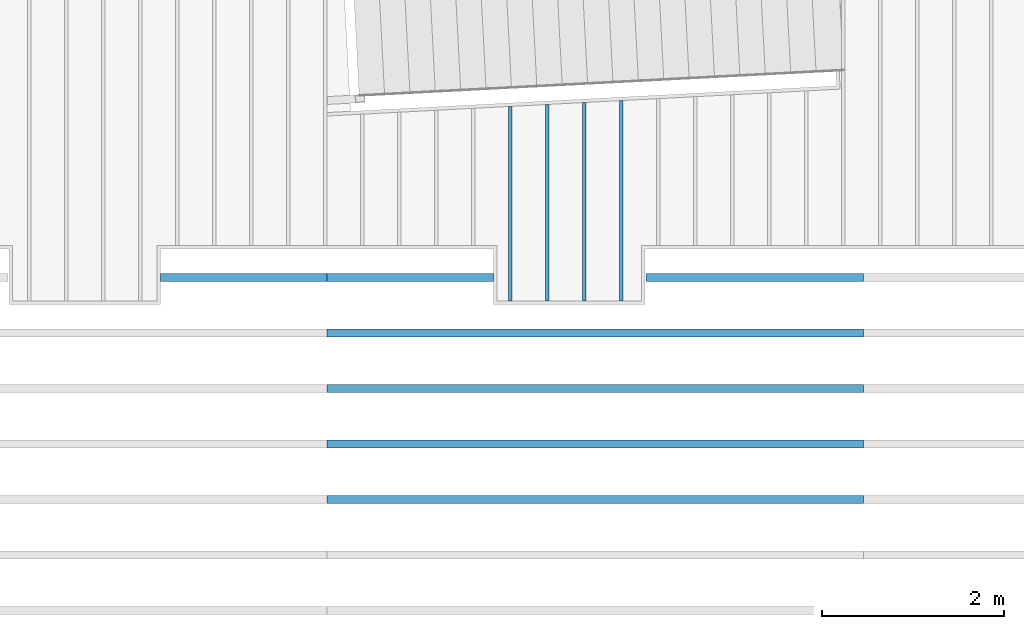
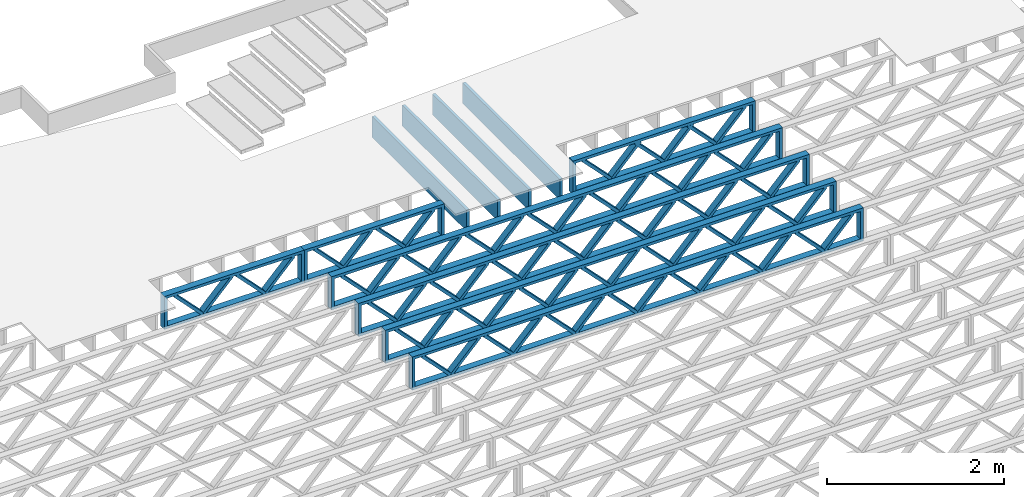
# One storey, part 9 of 23: 11 beams, 3 elements without a shape of their own.
"""IFC4 building model written with IfcOpenShell, lengths in feet."""

from ifc_helpers import new_model, entity, si_unit, converted_unit, derived_unit, direction, frame, frame_2d, origin, origin_2d_with_axis, place, context, subcontext, project, spatial, rectangle, extrude, source, transform, mapped, material, material_profile, profile_set, profile_usage, type_object, type_shapes, element, aggregate, save


model = new_model("IFC4")

# Units and contexts
model_context = context("Model", 3, precision=0.0001, world=origin(), true_north=direction((6.12303176911189e-17, 1.0)))
body_context = subcontext(model_context, "Body", "Model", "MODEL_VIEW")
ifc_project = project(units=[converted_unit("LENGTHUNIT", "FOOT", entity("IfcRatioMeasure", 0.3048), si_unit("LENGTHUNIT", "METRE"), dimensions=[1, 0, 0, 0, 0, 0, 0]), converted_unit("AREAUNIT", "SQUARE FOOT", entity("IfcRatioMeasure", 0.09290304), si_unit("AREAUNIT", "SQUARE_METRE"), dimensions=[2, 0, 0, 0, 0, 0, 0]), converted_unit("VOLUMEUNIT", "CUBIC FOOT", entity("IfcRatioMeasure", 0.028316846592), si_unit("VOLUMEUNIT", "CUBIC_METRE"), dimensions=[3, 0, 0, 0, 0, 0, 0]), converted_unit("PLANEANGLEUNIT", "DEGREE", entity("IfcRatioMeasure", 0.0174532925199433), si_unit("PLANEANGLEUNIT", "RADIAN"), dimensions=[0, 0, 0, 0, 0, 0, 0]), si_unit("MASSUNIT", "GRAM", prefix="KILO"), derived_unit("MASSDENSITYUNIT", [(si_unit("MASSUNIT", "GRAM", prefix="KILO"), 1), (si_unit("LENGTHUNIT", "METRE"), -3)]), derived_unit("MOMENTOFINERTIAUNIT", [(si_unit("LENGTHUNIT", "METRE"), 4)]), si_unit("TIMEUNIT", "SECOND"), si_unit("FREQUENCYUNIT", "HERTZ"), si_unit("THERMODYNAMICTEMPERATUREUNIT", "DEGREE_CELSIUS"), derived_unit("THERMALTRANSMITTANCEUNIT", [(si_unit("MASSUNIT", "GRAM", prefix="KILO"), 1), (si_unit("THERMODYNAMICTEMPERATUREUNIT", "KELVIN"), -1), (si_unit("TIMEUNIT", "SECOND"), -3)]), derived_unit("VOLUMETRICFLOWRATEUNIT", [(si_unit("LENGTHUNIT", "METRE"), 3), (si_unit("TIMEUNIT", "SECOND"), -1)]), si_unit("ELECTRICCURRENTUNIT", "AMPERE"), si_unit("ELECTRICVOLTAGEUNIT", "VOLT"), si_unit("POWERUNIT", "WATT"), si_unit("FORCEUNIT", "NEWTON"), si_unit("ILLUMINANCEUNIT", "LUX"), si_unit("LUMINOUSFLUXUNIT", "LUMEN"), si_unit("LUMINOUSINTENSITYUNIT", "CANDELA"), derived_unit("USERDEFINED", [(si_unit("MASSUNIT", "GRAM", prefix="KILO"), -1), (si_unit("LENGTHUNIT", "METRE"), -2), (si_unit("TIMEUNIT", "SECOND"), 3), (si_unit("LUMINOUSFLUXUNIT", "LUMEN"), 1)]), derived_unit("LINEARVELOCITYUNIT", [(si_unit("LENGTHUNIT", "METRE"), 1), (si_unit("TIMEUNIT", "SECOND"), -1)]), si_unit("PRESSUREUNIT", "PASCAL"), derived_unit("USERDEFINED", [(si_unit("LENGTHUNIT", "METRE"), -2), (si_unit("MASSUNIT", "GRAM", prefix="KILO"), 1), (si_unit("TIMEUNIT", "SECOND"), -2)]), derived_unit("LINEARFORCEUNIT", [(si_unit("MASSUNIT", "GRAM", prefix="KILO"), 1), (si_unit("LENGTHUNIT", "METRE"), 1), (si_unit("TIMEUNIT", "SECOND"), -2), (si_unit("LENGTHUNIT", "METRE"), -1)]), derived_unit("PLANARFORCEUNIT", [(si_unit("MASSUNIT", "GRAM", prefix="KILO"), 1), (si_unit("LENGTHUNIT", "METRE"), 1), (si_unit("TIMEUNIT", "SECOND"), -2), (si_unit("LENGTHUNIT", "METRE"), -2)])], contexts=[model_context])

# Site, building, storey
site_placement = place(None, origin())
site = spatial("IfcSite", under=ifc_project, at=site_placement, CompositionType="ELEMENT")
building_placement = place(site_placement, origin())
building = spatial("IfcBuilding", under=site, at=building_placement, CompositionType="ELEMENT")
storey_placement = place(building_placement, frame((0.0, 0.0, 10.8020833333333)))
storey = spatial("IfcBuildingStorey", under=building, at=storey_placement, Name="2ND FLOOR", CompositionType="ELEMENT", Elevation=10.8020833333333)

# Assembly, beams
assembly_1_placement = place(storey_placement, origin())
assembly_1 = element("IfcElementAssembly", 1, at=assembly_1_placement, inside=storey, Name="Structural Beam System:Structural Framing System", ObjectType="Structural Beam System:Structural Framing System", AssemblyPlace="NOTDEFINED", PredefinedType="BEAM_GRID")
ifc_material_1 = material(Name="WOOD TRUSS", Category="Materials")
ifc_material_profile_1 = material_profile(ifc_material_1, rectangle(XDim=1.73473973950632, YDim=0.125, at=frame_2d((-1.11022302462516e-16, 8.32667268468867e-17), x_axis=(1.0, 0.0))))
ifc_material_profile_2 = material_profile(ifc_material_1, rectangle(XDim=1.73473973950633, YDim=0.125, at=frame_2d((-1.11022302462516e-16, 8.32667268468867e-17), x_axis=(1.0, 0.0))))
ifc_material_profile_3 = material_profile(ifc_material_1, rectangle(XDim=1.73473973950632, YDim=0.125, at=frame_2d((-5.55111512312578e-17, 1.38777878078145e-16), x_axis=(1.0, 0.0))))
ifc_material_profile_4 = material_profile(ifc_material_1, rectangle(XDim=1.73473973950633, YDim=0.125, at=frame_2d((-1.11022302462516e-16, 8.32667268468867e-17), x_axis=(1.0, 0.0))))
ifc_material_profile_5 = material_profile(ifc_material_1, rectangle(XDim=1.73473973950632, YDim=0.125, at=frame_2d((-1.11022302462516e-16, 8.32667268468867e-17), x_axis=(1.0, 0.0))))
ifc_material_profile_6 = material_profile(ifc_material_1, rectangle(XDim=1.73473973950633, YDim=0.125, at=frame_2d((-2.77555756156289e-16, 3.05311331771918e-16), x_axis=(1.0, 0.0))))
ifc_material_profile_7 = material_profile(ifc_material_1, rectangle(XDim=1.73473973950632, YDim=0.124999999999999, at=frame_2d((-3.88578058618805e-16, -2.4980018054066e-16), x_axis=(1.0, 0.0))))
ifc_material_profile_8 = material_profile(ifc_material_1, rectangle(XDim=1.73473973950633, YDim=0.125, at=frame_2d((2.77555756156289e-16, -3.05311331771918e-16), x_axis=(1.0, 0.0))))
ifc_material_profile_9 = material_profile(ifc_material_1, rectangle(XDim=1.73473973950632, YDim=0.124999999999999, at=frame_2d((-1.11022302462516e-16, 8.32667268468867e-17), x_axis=(1.0, 0.0))))
ifc_material_profile_10 = material_profile(ifc_material_1, rectangle(XDim=1.73473973950633, YDim=0.125, at=origin_2d_with_axis()))
ifc_material_profile_11 = material_profile(ifc_material_1, rectangle(XDim=0.124999999999982, YDim=0.291666666666668, at=origin_2d_with_axis()))
ifc_material_profile_12 = material_profile(ifc_material_1, rectangle(XDim=0.124999999999932, YDim=0.291666666666664, at=origin_2d_with_axis()))
ifc_material_profile_13 = material_profile(ifc_material_1, rectangle(XDim=1.25000000000002, YDim=0.29166666666667, at=origin_2d_with_axis()))
ifc_material_profile_14 = material_profile(ifc_material_1, rectangle(XDim=1.25000000000004, YDim=0.291666666666667, at=origin_2d_with_axis()))
ifc_profile_set_1 = profile_set([ifc_material_profile_1, ifc_material_profile_2, ifc_material_profile_3, ifc_material_profile_4, ifc_material_profile_5, ifc_material_profile_6, ifc_material_profile_7, ifc_material_profile_8, ifc_material_profile_9, ifc_material_profile_10, ifc_material_profile_11, ifc_material_profile_12, ifc_material_profile_13, ifc_material_profile_14])
ifc_profile_usage_1 = profile_usage(ifc_profile_set_1, cardinal=8)
beam_type_1 = type_object("IfcBeamType", PredefinedType="BEAM", material=ifc_profile_set_1)
shared_shape_1 = source(origin(), body_context, "Body", "SweptSolid", [
    extrude(rectangle(XDim=1.73473973950632, YDim=0.125, at=frame_2d((-5.55111512312578e-17, 1.38777878078145e-16), x_axis=(1.0, 0.0))), frame((0.625142936836962, -0.145833333333334, 0.0), z_axis=(0.0, 1.0, 0.0), x_axis=(0.693383046997606, 0.0, 0.720569184836762)), (0.0, 0.0, 1.0), 0.291666666666667),
    extrude(rectangle(XDim=1.73473973950633, YDim=0.125, at=frame_2d((-1.11022302462516e-16, 8.32667268468867e-17), x_axis=(1.0, 0.0))), frame((-0.625142936836309, -0.145833333333334, 0.0), z_axis=(0.0, 1.0, 0.0), x_axis=(0.69338304699761, 0.0, -0.720569184836758)), (0.0, 0.0, 1.0), 0.291666666666667),
    extrude(rectangle(XDim=1.73473973950632, YDim=0.125, at=frame_2d((-1.11022302462516e-16, 8.32667268468867e-17), x_axis=(1.0, 0.0))), frame((2.87514283803796, -0.145833333333334, 0.0), z_axis=(0.0, 1.0, 0.0), x_axis=(0.693383046997606, 0.0, 0.720569184836762)), (0.0, 0.0, 1.0), 0.291666666666667),
    extrude(rectangle(XDim=1.73473973950633, YDim=0.125, at=frame_2d((-1.11022302462516e-16, 8.32667268468867e-17), x_axis=(1.0, 0.0))), frame((1.62485696436469, -0.145833333333334, 0.0), z_axis=(0.0, 1.0, 0.0), x_axis=(0.69338304699761, 0.0, -0.720569184836758)), (0.0, 0.0, 1.0), 0.291666666666667),
    extrude(rectangle(XDim=1.73473973950632, YDim=0.125, at=frame_2d((-1.11022302462516e-16, 8.32667268468867e-17), x_axis=(1.0, 0.0))), frame((-1.62485696436403, -0.145833333333334, 0.0), z_axis=(0.0, 1.0, 0.0), x_axis=(0.693383046997606, 0.0, 0.720569184836762)), (0.0, 0.0, 1.0), 0.291666666666667),
    extrude(rectangle(XDim=1.73473973950633, YDim=0.125, at=origin_2d_with_axis()), frame((-2.87514283803731, -0.145833333333334, 0.0), z_axis=(0.0, 1.0, 0.0), x_axis=(0.69338304699761, 0.0, -0.720569184836758)), (0.0, 0.0, 1.0), 0.291666666666667),
    extrude(rectangle(XDim=0.124999999999982, YDim=0.291666666666668, at=origin_2d_with_axis()), frame((-3.91666656786758, 0.0, 0.687500000000054), z_axis=(1.0, 0.0, 0.0), x_axis=(0.0, 0.0, -1.0)), (0.0, 0.0, 1.0), 7.83333313573516),
    extrude(rectangle(XDim=0.124999999999932, YDim=0.291666666666664, at=origin_2d_with_axis()), frame((-3.91666656786737, 0.0, -0.687499999999984), z_axis=(1.0, 0.0, 0.0), x_axis=(0.0, 0.0, -1.0)), (0.0, 0.0, 1.0), 7.83333313573495),
    extrude(rectangle(XDim=1.25000000000002, YDim=0.29166666666667, at=origin_2d_with_axis()), frame((3.79166656786756, 0.0, 0.0), z_axis=(1.0, 0.0, 0.0), x_axis=(0.0, 0.0, -1.0)), (0.0, 0.0, 1.0), 0.12500000000002),
    extrude(rectangle(XDim=1.25000000000004, YDim=0.291666666666667, at=origin_2d_with_axis()), frame((-3.91666656786758, 0.0, 0.0), z_axis=(1.0, 0.0, 0.0), x_axis=(0.0, 0.0, -1.0)), (0.0, 0.0, 1.0), 0.125000000000023),
])
type_shapes(beam_type_1, [shared_shape_1])
beam_1_placement = place(assembly_1_placement, frame((-168.321493720097, 957.861934882651, -0.947916666666657), z_axis=(0.0, 0.0, 1.0), x_axis=(-1.0, 0.0, 0.0)))
beam_1 = element("IfcBeam", 2, at=beam_1_placement, type_object=beam_type_1, material=ifc_profile_usage_1, PredefinedType="BEAM", context=body_context, shape_type="MappedRepresentation", body=[
    mapped(shared_shape_1, transform((0.0, 0.0, 0.0), scale=1.0)),
])
ifc_profile_usage_2 = profile_usage(ifc_profile_set_1, cardinal=8)
beam_type_2 = type_object("IfcBeamType", PredefinedType="BEAM", material=ifc_profile_set_1)
shared_shape_2 = source(origin(), body_context, "Body", "SweptSolid", [
    extrude(rectangle(XDim=1.73473973950632, YDim=0.125, at=frame_2d((0.0, 1.66533453693773e-16), x_axis=(1.0, 0.0))), frame((1.95847612494153, -0.145833333333334, 0.0), z_axis=(0.0, 1.0, 0.0), x_axis=(0.693383046997606, 0.0, 0.720569184836762)), (0.0, 0.0, 1.0), 0.291666666666667),
    extrude(rectangle(XDim=1.73473973950633, YDim=0.125, at=frame_2d((-5.55111512312578e-17, 8.32667268468867e-17), x_axis=(1.0, 0.0))), frame((0.708190251268258, -0.145833333333334, 0.0), z_axis=(0.0, 1.0, 0.0), x_axis=(0.69338304699761, 0.0, -0.720569184836758)), (0.0, 0.0, 1.0), 0.291666666666667),
    extrude(rectangle(XDim=1.73473973950632, YDim=0.125, at=frame_2d((0.0, 1.66533453693773e-16), x_axis=(1.0, 0.0))), frame((-0.708190251267602, -0.145833333333334, 0.0), z_axis=(0.0, 1.0, 0.0), x_axis=(0.693383046997606, 0.0, 0.720569184836762)), (0.0, 0.0, 1.0), 0.291666666666667),
    extrude(rectangle(XDim=1.73473973950633, YDim=0.125, at=frame_2d((-2.22044604925031e-16, 2.22044604925031e-16), x_axis=(1.0, 0.0))), frame((-1.95847612494087, -0.145833333333334, 0.0), z_axis=(0.0, 1.0, 0.0), x_axis=(0.69338304699761, 0.0, -0.720569184836758)), (0.0, 0.0, 1.0), 0.291666666666666),
    extrude(rectangle(XDim=0.124999999999982, YDim=0.291666666666668, at=origin_2d_with_axis()), frame((-2.99999985477115, 0.0, 0.687500000000054), z_axis=(1.0, 0.0, 0.0), x_axis=(0.0, 0.0, -1.0)), (0.0, 0.0, 1.0), 5.99999970954229),
    extrude(rectangle(XDim=0.124999999999932, YDim=0.291666666666664, at=origin_2d_with_axis()), frame((-2.99999985477093, 0.0, -0.687499999999984), z_axis=(1.0, 0.0, 0.0), x_axis=(0.0, 0.0, -1.0)), (0.0, 0.0, 1.0), 5.99999970954208),
    extrude(rectangle(XDim=1.25000000000002, YDim=0.29166666666667, at=origin_2d_with_axis()), frame((2.87499985477113, 0.0, 0.0), z_axis=(1.0, 0.0, 0.0), x_axis=(0.0, 0.0, -1.0)), (0.0, 0.0, 1.0), 0.12500000000002),
    extrude(rectangle(XDim=1.25000000000004, YDim=0.291666666666667, at=origin_2d_with_axis()), frame((-2.99999985477115, 0.0, 0.0), z_axis=(1.0, 0.0, 0.0), x_axis=(0.0, 0.0, -1.0)), (0.0, 0.0, 1.0), 0.125000000000023),
])
type_shapes(beam_type_2, [shared_shape_2])
beam_2_placement = place(assembly_1_placement, frame((-180.738160630791, 957.861934882651, -0.947916666666648), z_axis=(0.0, 0.0, 1.0), x_axis=(-1.0, 0.0, 0.0)))
beam_2 = element("IfcBeam", 3, at=beam_2_placement, type_object=beam_type_2, material=ifc_profile_usage_2, PredefinedType="BEAM", context=body_context, shape_type="MappedRepresentation", body=[
    mapped(shared_shape_2, transform((0.0, 0.0, 0.0), scale=1.0)),
])
ifc_profile_usage_3 = profile_usage(ifc_profile_set_1, cardinal=8)
beam_type_3 = type_object("IfcBeamType", PredefinedType="BEAM", material=ifc_profile_set_1)
shared_shape_3 = source(origin(), body_context, "Body", "SweptSolid", [
    extrude(rectangle(XDim=1.73473973950632, YDim=0.124999999999999, at=frame_2d((5.55111512312578e-16, 7.21644966006352e-16), x_axis=(1.0, 0.0))), frame((5.95847627016997, -0.145833333333334, 0.0), z_axis=(0.0, 1.0, 0.0), x_axis=(0.693383046997606, 0.0, 0.720569184836762)), (0.0, 0.0, 1.0), 0.291666666666667),
    extrude(rectangle(XDim=1.73473973950633, YDim=0.125, at=origin_2d_with_axis()), frame((4.7081903964967, -0.145833333333334, 0.0), z_axis=(0.0, 1.0, 0.0), x_axis=(0.69338304699761, 0.0, -0.720569184836758)), (0.0, 0.0, 1.0), 0.291666666666666),
    extrude(rectangle(XDim=1.73473973950632, YDim=0.125, at=frame_2d((2.22044604925031e-16, 3.88578058618805e-16), x_axis=(1.0, 0.0))), frame((3.29180960350347, -0.145833333333334, 0.0), z_axis=(0.0, 1.0, 0.0), x_axis=(0.693383046997606, 0.0, 0.720569184836762)), (0.0, 0.0, 1.0), 0.291666666666667),
    extrude(rectangle(XDim=1.73473973950633, YDim=0.125, at=frame_2d((1.11022302462516e-16, -8.32667268468867e-17), x_axis=(1.0, 0.0))), frame((2.0415237298302, -0.145833333333334, 0.0), z_axis=(0.0, 1.0, 0.0), x_axis=(0.69338304699761, 0.0, -0.720569184836758)), (0.0, 0.0, 1.0), 0.291666666666667),
    extrude(rectangle(XDim=1.73473973950632, YDim=0.125, at=frame_2d((-5.55111512312578e-17, 1.38777878078145e-16), x_axis=(1.0, 0.0))), frame((0.625142936836964, -0.145833333333334, 0.0), z_axis=(0.0, 1.0, 0.0), x_axis=(0.693383046997606, 0.0, 0.720569184836762)), (0.0, 0.0, 1.0), 0.291666666666667),
    extrude(rectangle(XDim=1.73473973950633, YDim=0.125, at=frame_2d((-1.11022302462516e-16, 8.32667268468867e-17), x_axis=(1.0, 0.0))), frame((-0.625142936836306, -0.145833333333334, 0.0), z_axis=(0.0, 1.0, 0.0), x_axis=(0.69338304699761, 0.0, -0.720569184836758)), (0.0, 0.0, 1.0), 0.291666666666667),
    extrude(rectangle(XDim=1.73473973950632, YDim=0.125, at=frame_2d((-1.11022302462516e-16, 8.32667268468867e-17), x_axis=(1.0, 0.0))), frame((-2.04152372982954, -0.145833333333334, 0.0), z_axis=(0.0, 1.0, 0.0), x_axis=(0.693383046997606, 0.0, 0.720569184836762)), (0.0, 0.0, 1.0), 0.291666666666667),
    extrude(rectangle(XDim=1.73473973950633, YDim=0.125, at=origin_2d_with_axis()), frame((-3.29180960350281, -0.145833333333334, 0.0), z_axis=(0.0, 1.0, 0.0), x_axis=(0.69338304699761, 0.0, -0.720569184836758)), (0.0, 0.0, 1.0), 0.291666666666667),
    extrude(rectangle(XDim=1.73473973950632, YDim=0.124999999999999, at=frame_2d((-1.11022302462516e-16, 8.32667268468867e-17), x_axis=(1.0, 0.0))), frame((-4.70819039649604, -0.145833333333334, 0.0), z_axis=(0.0, 1.0, 0.0), x_axis=(0.693383046997606, 0.0, 0.720569184836762)), (0.0, 0.0, 1.0), 0.291666666666667),
    extrude(rectangle(XDim=1.73473973950633, YDim=0.125, at=frame_2d((-5.55111512312578e-16, 6.38378239159465e-16), x_axis=(1.0, 0.0))), frame((-5.95847627016931, -0.145833333333334, 0.0), z_axis=(0.0, 1.0, 0.0), x_axis=(0.69338304699761, 0.0, -0.720569184836758)), (0.0, 0.0, 1.0), 0.291666666666666),
    extrude(rectangle(XDim=1.73473973950632, YDim=0.125, at=frame_2d((-7.21644966006352e-16, -5.82867087928207e-16), x_axis=(1.0, 0.0))), frame((8.62514293683647, -0.145833333333334, 0.0), z_axis=(0.0, 1.0, 0.0), x_axis=(0.693383046997607, 0.0, 0.720569184836761)), (0.0, 0.0, 1.0), 0.291666666666667),
    extrude(rectangle(XDim=1.73473973950633, YDim=0.125, at=origin_2d_with_axis()), frame((7.3748570631632, -0.145833333333334, 0.0), z_axis=(0.0, 1.0, 0.0), x_axis=(0.69338304699761, 0.0, -0.720569184836758)), (0.0, 0.0, 1.0), 0.291666666666666),
    extrude(rectangle(XDim=1.73473973950632, YDim=0.124999999999999, at=frame_2d((-1.11022302462516e-16, 8.32667268468867e-17), x_axis=(1.0, 0.0))), frame((-7.37485706316255, -0.145833333333334, 0.0), z_axis=(0.0, 1.0, 0.0), x_axis=(0.693383046997606, 0.0, 0.720569184836762)), (0.0, 0.0, 1.0), 0.291666666666667),
    extrude(rectangle(XDim=1.73473973950633, YDim=0.125, at=origin_2d_with_axis()), frame((-8.62514293683582, -0.145833333333334, 0.0), z_axis=(0.0, 1.0, 0.0), x_axis=(0.69338304699761, 0.0, -0.720569184836758)), (0.0, 0.0, 1.0), 0.291666666666666),
    extrude(rectangle(XDim=0.124999999999982, YDim=0.291666666666668, at=origin_2d_with_axis()), frame((-9.66666666666609, 0.0, 0.687500000000054), z_axis=(1.0, 0.0, 0.0), x_axis=(0.0, 0.0, -1.0)), (0.0, 0.0, 1.0), 19.3333333333322),
    extrude(rectangle(XDim=0.124999999999932, YDim=0.291666666666664, at=origin_2d_with_axis()), frame((-9.66666666666588, 0.0, -0.687499999999984), z_axis=(1.0, 0.0, 0.0), x_axis=(0.0, 0.0, -1.0)), (0.0, 0.0, 1.0), 19.333333333332),
    extrude(rectangle(XDim=1.25000000000002, YDim=0.29166666666667, at=origin_2d_with_axis()), frame((9.54166666666607, 0.0, 0.0), z_axis=(1.0, 0.0, 0.0), x_axis=(0.0, 0.0, -1.0)), (0.0, 0.0, 1.0), 0.12500000000002),
    extrude(rectangle(XDim=1.25000000000004, YDim=0.291666666666667, at=origin_2d_with_axis()), frame((-9.66666666666609, 0.0, 0.0), z_axis=(1.0, 0.0, 0.0), x_axis=(0.0, 0.0, -1.0)), (0.0, 0.0, 1.0), 0.125000000000023),
])
type_shapes(beam_type_3, [shared_shape_3])
beam_3_placement = place(assembly_1_placement, frame((-174.071493818896, 953.861934882651, -0.947916666666657), z_axis=(0.0, 0.0, 1.0), x_axis=(-1.0, 0.0, 0.0)))
beam_3 = element("IfcBeam", 4, at=beam_3_placement, type_object=beam_type_3, material=ifc_profile_usage_3, PredefinedType="BEAM", context=body_context, shape_type="MappedRepresentation", body=[
    mapped(shared_shape_3, transform((0.0, 0.0, 0.0), scale=1.0)),
])
ifc_profile_usage_4 = profile_usage(ifc_profile_set_1, cardinal=8)
beam_4_placement = place(assembly_1_placement, frame((-174.071493818896, 951.861934882651, -0.947916666666657), z_axis=(0.0, 0.0, 1.0), x_axis=(-1.0, 0.0, 0.0)))
beam_4 = element("IfcBeam", 5, at=beam_4_placement, type_object=beam_type_3, material=ifc_profile_usage_4, PredefinedType="BEAM", context=body_context, shape_type="MappedRepresentation", body=[
    mapped(shared_shape_3, transform((0.0, 0.0, 0.0), scale=1.0)),
])
ifc_profile_usage_5 = profile_usage(ifc_profile_set_1, cardinal=8)
beam_5_placement = place(assembly_1_placement, frame((-174.071493818896, 949.861934882651, -0.947916666666657), z_axis=(0.0, 0.0, 1.0), x_axis=(-1.0, 0.0, 0.0)))
beam_5 = element("IfcBeam", 6, at=beam_5_placement, type_object=beam_type_3, material=ifc_profile_usage_5, PredefinedType="BEAM", context=body_context, shape_type="MappedRepresentation", body=[
    mapped(shared_shape_3, transform((0.0, 0.0, 0.0), scale=1.0)),
])
ifc_profile_usage_6 = profile_usage(ifc_profile_set_1, cardinal=8)
beam_type_4 = type_object("IfcBeamType", PredefinedType="BEAM", material=ifc_profile_set_1)
shared_shape_4 = source(origin(), body_context, "Body", "SweptSolid", [
    extrude(rectangle(XDim=1.73473973950632, YDim=0.124999999999999, at=frame_2d((5.55111512312578e-16, 7.21644966006352e-16), x_axis=(1.0, 0.0))), frame((5.95847627016997, -0.145833333333334, 0.0), z_axis=(0.0, 1.0, 0.0), x_axis=(0.693383046997606, 0.0, 0.720569184836762)), (0.0, 0.0, 1.0), 0.291666666666667),
    extrude(rectangle(XDim=1.73473973950633, YDim=0.125, at=origin_2d_with_axis()), frame((4.7081903964967, -0.145833333333334, 0.0), z_axis=(0.0, 1.0, 0.0), x_axis=(0.69338304699761, 0.0, -0.720569184836758)), (0.0, 0.0, 1.0), 0.291666666666666),
    extrude(rectangle(XDim=1.73473973950632, YDim=0.125, at=frame_2d((2.22044604925031e-16, 3.88578058618805e-16), x_axis=(1.0, 0.0))), frame((3.29180960350347, -0.145833333333334, 0.0), z_axis=(0.0, 1.0, 0.0), x_axis=(0.693383046997606, 0.0, 0.720569184836762)), (0.0, 0.0, 1.0), 0.291666666666667),
    extrude(rectangle(XDim=1.73473973950633, YDim=0.125, at=frame_2d((1.11022302462516e-16, -8.32667268468867e-17), x_axis=(1.0, 0.0))), frame((2.0415237298302, -0.145833333333334, 0.0), z_axis=(0.0, 1.0, 0.0), x_axis=(0.69338304699761, 0.0, -0.720569184836758)), (0.0, 0.0, 1.0), 0.291666666666667),
    extrude(rectangle(XDim=1.73473973950632, YDim=0.125, at=frame_2d((-5.55111512312578e-17, 1.38777878078145e-16), x_axis=(1.0, 0.0))), frame((0.625142936836964, -0.145833333333334, 0.0), z_axis=(0.0, 1.0, 0.0), x_axis=(0.693383046997606, 0.0, 0.720569184836762)), (0.0, 0.0, 1.0), 0.291666666666667),
    extrude(rectangle(XDim=1.73473973950633, YDim=0.125, at=frame_2d((-1.11022302462516e-16, 8.32667268468867e-17), x_axis=(1.0, 0.0))), frame((-0.625142936836306, -0.145833333333334, 0.0), z_axis=(0.0, 1.0, 0.0), x_axis=(0.69338304699761, 0.0, -0.720569184836758)), (0.0, 0.0, 1.0), 0.291666666666667),
    extrude(rectangle(XDim=1.73473973950632, YDim=0.125, at=frame_2d((-1.11022302462516e-16, 8.32667268468867e-17), x_axis=(1.0, 0.0))), frame((-2.04152372982954, -0.145833333333334, 0.0), z_axis=(0.0, 1.0, 0.0), x_axis=(0.693383046997606, 0.0, 0.720569184836762)), (0.0, 0.0, 1.0), 0.291666666666667),
    extrude(rectangle(XDim=1.73473973950633, YDim=0.125, at=origin_2d_with_axis()), frame((-3.29180960350281, -0.145833333333334, 0.0), z_axis=(0.0, 1.0, 0.0), x_axis=(0.69338304699761, 0.0, -0.720569184836758)), (0.0, 0.0, 1.0), 0.291666666666667),
    extrude(rectangle(XDim=1.73473973950632, YDim=0.124999999999999, at=frame_2d((-1.11022302462516e-16, 8.32667268468867e-17), x_axis=(1.0, 0.0))), frame((-4.70819039649604, -0.145833333333334, 0.0), z_axis=(0.0, 1.0, 0.0), x_axis=(0.693383046997606, 0.0, 0.720569184836762)), (0.0, 0.0, 1.0), 0.291666666666667),
    extrude(rectangle(XDim=1.73473973950633, YDim=0.125, at=frame_2d((-5.55111512312578e-16, 6.38378239159465e-16), x_axis=(1.0, 0.0))), frame((-5.95847627016931, -0.145833333333334, 0.0), z_axis=(0.0, 1.0, 0.0), x_axis=(0.69338304699761, 0.0, -0.720569184836758)), (0.0, 0.0, 1.0), 0.291666666666666),
    extrude(rectangle(XDim=1.73473973950632, YDim=0.125, at=frame_2d((-7.21644966006352e-16, -5.82867087928207e-16), x_axis=(1.0, 0.0))), frame((8.62514293683647, -0.145833333333334, 0.0), z_axis=(0.0, 1.0, 0.0), x_axis=(0.693383046997607, 0.0, 0.720569184836761)), (0.0, 0.0, 1.0), 0.291666666666667),
    extrude(rectangle(XDim=1.73473973950633, YDim=0.125, at=origin_2d_with_axis()), frame((7.3748570631632, -0.145833333333334, 0.0), z_axis=(0.0, 1.0, 0.0), x_axis=(0.69338304699761, 0.0, -0.720569184836758)), (0.0, 0.0, 1.0), 0.291666666666666),
    extrude(rectangle(XDim=1.73473973950632, YDim=0.124999999999999, at=frame_2d((-1.11022302462516e-16, 8.32667268468867e-17), x_axis=(1.0, 0.0))), frame((-7.37485706316255, -0.145833333333334, 0.0), z_axis=(0.0, 1.0, 0.0), x_axis=(0.693383046997606, 0.0, 0.720569184836762)), (0.0, 0.0, 1.0), 0.291666666666667),
    extrude(rectangle(XDim=1.73473973950633, YDim=0.125, at=origin_2d_with_axis()), frame((-8.62514293683582, -0.145833333333334, 0.0), z_axis=(0.0, 1.0, 0.0), x_axis=(0.69338304699761, 0.0, -0.720569184836758)), (0.0, 0.0, 1.0), 0.291666666666666),
    extrude(rectangle(XDim=0.124999999999982, YDim=0.291666666666668, at=origin_2d_with_axis()), frame((-9.66666666666609, 0.0, 0.687500000000054), z_axis=(1.0, 0.0, 0.0), x_axis=(0.0, 0.0, -1.0)), (0.0, 0.0, 1.0), 19.3333333333322),
    extrude(rectangle(XDim=0.124999999999932, YDim=0.291666666666664, at=origin_2d_with_axis()), frame((-9.66666666666588, 0.0, -0.687499999999984), z_axis=(1.0, 0.0, 0.0), x_axis=(0.0, 0.0, -1.0)), (0.0, 0.0, 1.0), 19.333333333332),
    extrude(rectangle(XDim=1.25000000000002, YDim=0.29166666666667, at=origin_2d_with_axis()), frame((9.54166666666607, 0.0, 0.0), z_axis=(1.0, 0.0, 0.0), x_axis=(0.0, 0.0, -1.0)), (0.0, 0.0, 1.0), 0.12500000000002),
    extrude(rectangle(XDim=1.25000000000004, YDim=0.291666666666667, at=origin_2d_with_axis()), frame((-9.66666666666609, 0.0, 0.0), z_axis=(1.0, 0.0, 0.0), x_axis=(0.0, 0.0, -1.0)), (0.0, 0.0, 1.0), 0.125000000000023),
])
type_shapes(beam_type_4, [shared_shape_4])
beam_6_placement = place(assembly_1_placement, frame((-174.071493818896, 955.861934882651, -0.947916666666657), z_axis=(0.0, 0.0, 1.0), x_axis=(-1.0, 0.0, 0.0)))
beam_6 = element("IfcBeam", 7, at=beam_6_placement, type_object=beam_type_4, material=ifc_profile_usage_6, PredefinedType="BEAM", context=body_context, shape_type="MappedRepresentation", body=[
    mapped(shared_shape_4, transform((0.0, 0.0, 0.0), scale=1.0)),
])
aggregate(assembly_1, [beam_1, beam_2, beam_6, beam_3, beam_4, beam_5])

# Assembly, beam
assembly_2_placement = place(storey_placement, origin())
assembly_2 = element("IfcElementAssembly", 8, at=assembly_2_placement, inside=storey, Name="Structural Beam System:Structural Framing System", ObjectType="Structural Beam System:Structural Framing System", AssemblyPlace="NOTDEFINED", PredefinedType="BEAM_GRID")
ifc_profile_usage_7 = profile_usage(ifc_profile_set_1, cardinal=8)
beam_type_5 = type_object("IfcBeamType", PredefinedType="BEAM", material=ifc_profile_set_1)
shared_shape_5 = source(origin(), body_context, "Body", "SweptSolid", [
    extrude(rectangle(XDim=1.73473973950632, YDim=0.125, at=frame_2d((0.0, 1.66533453693773e-16), x_axis=(1.0, 0.0))), frame((1.95847610985504, -0.145833333333334, 0.0), z_axis=(0.0, 1.0, 0.0), x_axis=(0.693383046997606, 0.0, 0.720569184836762)), (0.0, 0.0, 1.0), 0.291666666666667),
    extrude(rectangle(XDim=1.73473973950633, YDim=0.125, at=frame_2d((-5.55111512312578e-17, 8.32667268468867e-17), x_axis=(1.0, 0.0))), frame((0.708190236181772, -0.145833333333334, 0.0), z_axis=(0.0, 1.0, 0.0), x_axis=(0.69338304699761, 0.0, -0.720569184836758)), (0.0, 0.0, 1.0), 0.291666666666667),
    extrude(rectangle(XDim=1.73473973950632, YDim=0.125, at=frame_2d((0.0, 1.66533453693773e-16), x_axis=(1.0, 0.0))), frame((-0.708190236181118, -0.145833333333334, 0.0), z_axis=(0.0, 1.0, 0.0), x_axis=(0.693383046997606, 0.0, 0.720569184836762)), (0.0, 0.0, 1.0), 0.291666666666667),
    extrude(rectangle(XDim=1.73473973950633, YDim=0.125, at=frame_2d((-2.22044604925031e-16, 2.22044604925031e-16), x_axis=(1.0, 0.0))), frame((-1.95847610985439, -0.145833333333334, 0.0), z_axis=(0.0, 1.0, 0.0), x_axis=(0.69338304699761, 0.0, -0.720569184836758)), (0.0, 0.0, 1.0), 0.291666666666666),
    extrude(rectangle(XDim=0.124999999999982, YDim=0.291666666666668, at=origin_2d_with_axis()), frame((-2.99999983968466, 0.0, 0.687500000000054), z_axis=(1.0, 0.0, 0.0), x_axis=(0.0, 0.0, -1.0)), (0.0, 0.0, 1.0), 5.99999967936932),
    extrude(rectangle(XDim=0.124999999999932, YDim=0.291666666666664, at=origin_2d_with_axis()), frame((-2.99999983968445, 0.0, -0.687499999999984), z_axis=(1.0, 0.0, 0.0), x_axis=(0.0, 0.0, -1.0)), (0.0, 0.0, 1.0), 5.99999967936911),
    extrude(rectangle(XDim=1.25000000000002, YDim=0.29166666666667, at=origin_2d_with_axis()), frame((2.87499983968464, 0.0, 0.0), z_axis=(1.0, 0.0, 0.0), x_axis=(0.0, 0.0, -1.0)), (0.0, 0.0, 1.0), 0.12500000000002),
    extrude(rectangle(XDim=1.25000000000004, YDim=0.291666666666667, at=origin_2d_with_axis()), frame((-2.99999983968466, 0.0, 0.0), z_axis=(1.0, 0.0, 0.0), x_axis=(0.0, 0.0, -1.0)), (0.0, 0.0, 1.0), 0.125000000000023),
])
type_shapes(beam_type_5, [shared_shape_5])
beam_7_placement = place(assembly_2_placement, frame((-186.738160325248, 957.861934882651, -0.947916666666872)))
beam_7 = element("IfcBeam", 9, at=beam_7_placement, type_object=beam_type_5, material=ifc_profile_usage_7, PredefinedType="BEAM", context=body_context, shape_type="MappedRepresentation", body=[
    mapped(shared_shape_5, transform((0.0, 0.0, 0.0), scale=1.0)),
])
aggregate(assembly_2, [beam_7])

# Assembly, beams
assembly_3_placement = place(storey_placement, origin())
assembly_3 = element("IfcElementAssembly", 10, at=assembly_3_placement, inside=storey, Name="Structural Beam System:Structural Framing System", ObjectType="Structural Beam System:Structural Framing System", AssemblyPlace="NOTDEFINED", PredefinedType="BEAM_GRID")
ifc_material_2 = material(Category="Materials")
ifc_material_profile_15 = material_profile(ifc_material_2, rectangle(XDim=0.9375, YDim=0.125000000000011, at=origin_2d_with_axis()))
ifc_profile_set_2 = profile_set([ifc_material_profile_15])
ifc_profile_usage_8 = profile_usage(ifc_profile_set_2, cardinal=8)
beam_type_6 = type_object("IfcBeamType", PredefinedType="BEAM", material=ifc_profile_set_2)
shared_shape_6 = source(origin(), body_context, "Body", "SweptSolid", [
    extrude(rectangle(XDim=0.9375, YDim=0.125000000000011, at=origin_2d_with_axis()), frame((-3.50318604616604, 0.0, 0.0), z_axis=(1.0, 0.0, 0.0), x_axis=(0.0, 0.0, -1.0)), (0.0, 0.0, 1.0), 7.00637209233207),
])
type_shapes(beam_type_6, [shared_shape_6])
beam_8_placement = place(assembly_3_placement, frame((-177.133993818795, 960.531787595484, -0.729166666666744), z_axis=(0.0, 0.0, 1.0), x_axis=(0.0, 1.0, 0.0)))
beam_8 = element("IfcBeam", 11, at=beam_8_placement, type_object=beam_type_6, material=ifc_profile_usage_8, PredefinedType="BEAM", context=body_context, shape_type="MappedRepresentation", body=[
    mapped(shared_shape_6, transform((0.0, 0.0, 0.0), scale=1.0)),
])
ifc_profile_usage_9 = profile_usage(ifc_profile_set_2, cardinal=8)
beam_type_7 = type_object("IfcBeamType", PredefinedType="BEAM", material=ifc_profile_set_2)
shared_shape_7 = source(origin(), body_context, "Body", "SweptSolid", [
    extrude(rectangle(XDim=0.9375, YDim=0.125000000000011, at=origin_2d_with_axis()), frame((-3.53812456568801, 0.0, 0.0), z_axis=(1.0, 0.0, 0.0), x_axis=(0.0, 0.0, -1.0)), (0.0, 0.0, 1.0), 7.07624913137602),
])
type_shapes(beam_type_7, [shared_shape_7])
beam_9_placement = place(assembly_3_placement, frame((-175.800660485462, 960.566726115006, -0.729166666666744), z_axis=(0.0, 0.0, 1.0), x_axis=(0.0, 1.0, 0.0)))
beam_9 = element("IfcBeam", 12, at=beam_9_placement, type_object=beam_type_7, material=ifc_profile_usage_9, PredefinedType="BEAM", context=body_context, shape_type="MappedRepresentation", body=[
    mapped(shared_shape_7, transform((0.0, 0.0, 0.0), scale=1.0)),
])
ifc_profile_usage_10 = profile_usage(ifc_profile_set_2, cardinal=8)
beam_type_8 = type_object("IfcBeamType", PredefinedType="BEAM", material=ifc_profile_set_2)
shared_shape_8 = source(origin(), body_context, "Body", "SweptSolid", [
    extrude(rectangle(XDim=0.9375, YDim=0.125000000000011, at=origin_2d_with_axis()), frame((-3.57306308520992, 0.0, 0.0), z_axis=(1.0, 0.0, 0.0), x_axis=(0.0, 0.0, -1.0)), (0.0, 0.0, 1.0), 7.14612617041985),
])
type_shapes(beam_type_8, [shared_shape_8])
beam_10_placement = place(assembly_3_placement, frame((-174.467327152129, 960.601664634528, -0.729166666666744), z_axis=(0.0, 0.0, 1.0), x_axis=(0.0, 1.0, 0.0)))
beam_10 = element("IfcBeam", 13, at=beam_10_placement, type_object=beam_type_8, material=ifc_profile_usage_10, PredefinedType="BEAM", context=body_context, shape_type="MappedRepresentation", body=[
    mapped(shared_shape_8, transform((0.0, 0.0, 0.0), scale=1.0)),
])
ifc_profile_usage_11 = profile_usage(ifc_profile_set_2, cardinal=8)
beam_type_9 = type_object("IfcBeamType", PredefinedType="BEAM", material=ifc_profile_set_2)
shared_shape_9 = source(origin(), body_context, "Body", "SweptSolid", [
    extrude(rectangle(XDim=0.9375, YDim=0.125000000000011, at=origin_2d_with_axis()), frame((-3.60800160473184, 0.0, 0.0), z_axis=(1.0, 0.0, 0.0), x_axis=(0.0, 0.0, -1.0)), (0.0, 0.0, 1.0), 7.21600320946368),
])
type_shapes(beam_type_9, [shared_shape_9])
beam_11_placement = place(assembly_3_placement, frame((-173.133993818795, 960.63660315405, -0.729166666666744), z_axis=(0.0, 0.0, 1.0), x_axis=(0.0, 1.0, 0.0)))
beam_11 = element("IfcBeam", 14, at=beam_11_placement, type_object=beam_type_9, material=ifc_profile_usage_11, PredefinedType="BEAM", context=body_context, shape_type="MappedRepresentation", body=[
    mapped(shared_shape_9, transform((0.0, 0.0, 0.0), scale=1.0)),
])
aggregate(assembly_3, [beam_8, beam_9, beam_10, beam_11])

save(model, "model.ifc")
